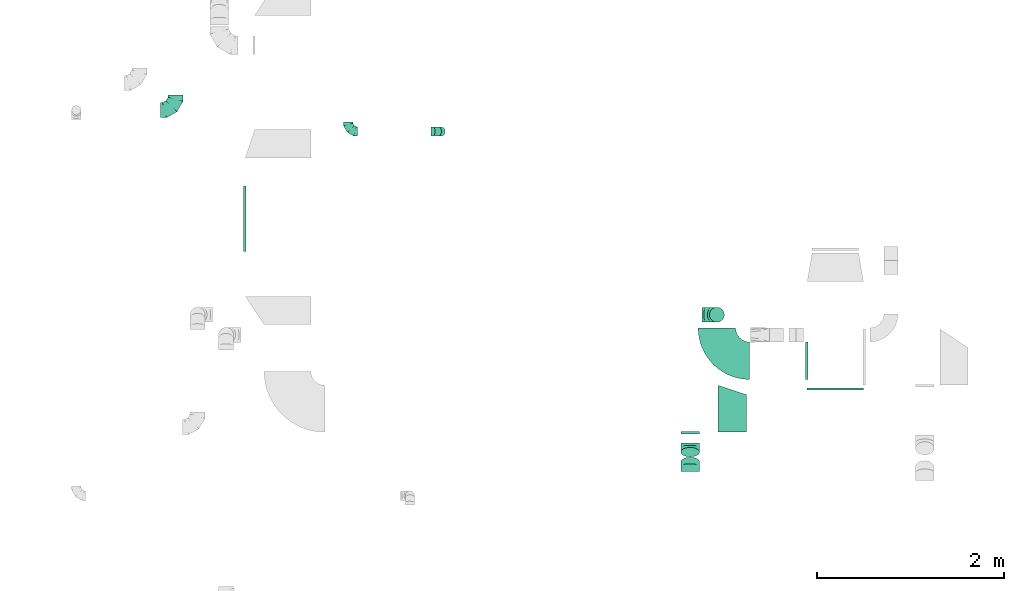
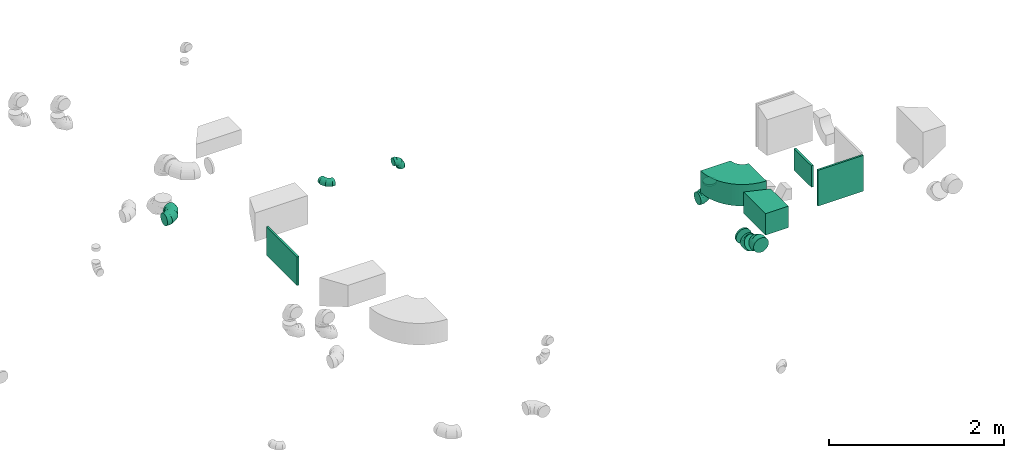
# One storey, part 9 of 32: 13 flow fittings.
"""IFC2X3 building model written with IfcOpenShell, lengths in millimetres."""

import ifcopenshell
import ifcopenshell.guid

model = None  # the IFC model being written
_history = None  # IfcOwnerHistory: only IFC2X3 demands one
_inside = {}  # id of a spatial element -> (the spatial element, [elements in it])
_under = {}  # id of a project, library or spatial element -> (it, [spatial elements below it])
_declared = {}  # id of a project -> (the project, [libraries it declares])
_typed = {}  # id of a type object -> (the type object, [elements of that type])
_made_of = {}  # id of a material, layer set ... -> (it, [elements and type objects made of it])


def new_model(schema):
    """Start an empty IFC model of exactly this schema.

    Asked for "IFC4X3", IfcOpenShell would pick the latest addendum, in which some entities
    have other attributes; the version numbers below select the first issue.
    IFC2X3 requires an IfcOwnerHistory on every rooted entity: one is made here for all.
    """
    global model, _history
    if schema == "IFC4X3":
        model = ifcopenshell.file(schema_version=(4, 3, 0, 0))
    else:
        model = ifcopenshell.file(schema=schema)
    _inside.clear()
    _under.clear()
    _declared.clear()
    _typed.clear()
    _made_of.clear()
    _history = None
    if model.schema == "IFC2X3":
        org = make("IfcOrganization", Name="unknown")
        user = make(
            "IfcPersonAndOrganization",
            ThePerson=make("IfcPerson", FamilyName="unknown"),
            TheOrganization=org,
        )
        app = make(
            "IfcApplication",
            ApplicationDeveloper=org,
            Version="unknown",
            ApplicationFullName="unknown",
            ApplicationIdentifier="unknown",
        )
        _history = make(
            "IfcOwnerHistory",
            OwningUser=user,
            OwningApplication=app,
            ChangeAction="ADDED",
            CreationDate=0,
        )
    return model


def make(cls, **values):
    """One entity of the class cls with the attributes given. An attribute that is None is left unset."""
    return model.create_entity(
        cls, **{name: value for name, value in values.items() if value is not None}
    )


def entity(cls, *values):
    """Any entity or typed value of the class cls, its attributes in the order of the schema. None: left unset."""
    e = model.create_entity(cls)
    for i, value in enumerate(values):
        if value is not None:
            e[i] = value
    return e


def rooted(cls, **values):
    """An entity with a GlobalId (a new one), such as an element, a storey or a relation."""
    return make(cls, GlobalId=ifcopenshell.guid.new(), OwnerHistory=_history, **values)


def si_unit(unit_type, name, prefix=None):
    """IfcSIUnit, for example si_unit("LENGTHUNIT", "METRE", prefix="MILLI")."""
    return make("IfcSIUnit", UnitType=unit_type, Prefix=prefix, Name=name)


def converted_unit(unit_type, name, factor, base, dimensions=None, offset=None):
    """IfcConversionBasedUnit, such as the inch: factor (a typed value) times the base unit."""
    return make(
        "IfcConversionBasedUnit"
        if offset is None
        else "IfcConversionBasedUnitWithOffset",
        ConversionOffset=offset,
        Dimensions=None
        if dimensions is None
        else entity("IfcDimensionalExponents", *dimensions),
        UnitType=unit_type,
        Name=name,
        ConversionFactor=make(
            "IfcMeasureWithUnit", ValueComponent=factor, UnitComponent=base
        ),
    )


def derived_unit(unit_type, elements):
    """IfcDerivedUnit: a product of units, each with its exponent."""
    return make(
        "IfcDerivedUnit",
        Elements=[
            make("IfcDerivedUnitElement", Unit=unit, Exponent=power)
            for unit, power in elements
        ],
        UnitType=unit_type,
    )


def assignment(units):
    """IfcUnitAssignment: the units of a project."""
    return None if units is None else make("IfcUnitAssignment", Units=units)


def point(xyz):
    """IfcCartesianPoint."""
    return None if xyz is None else make("IfcCartesianPoint", Coordinates=xyz)


def direction(xyz):
    """IfcDirection."""
    return None if xyz is None else make("IfcDirection", DirectionRatios=xyz)


def frame(location, z_axis=None, x_axis=None):
    """IfcAxis2Placement3D, a coordinate frame: its origin and axes. An axis left out is left unset."""
    return make(
        "IfcAxis2Placement3D",
        Location=point(location),
        Axis=direction(z_axis),
        RefDirection=direction(x_axis),
    )


def frame_2d(location, x_axis=None):
    """IfcAxis2Placement2D, a coordinate frame in the plane: its origin and x axis."""
    return make(
        "IfcAxis2Placement2D", Location=point(location), RefDirection=direction(x_axis)
    )


def origin():
    """The frame at (0, 0, 0) with its axes left unset."""
    return frame((0.0, 0.0, 0.0))


def origin_2d_with_axis():
    """The frame at (0, 0) in the plane with the x axis (1, 0) written out."""
    return frame_2d((0.0, 0.0), x_axis=(1.0, 0.0))


def place(relative_to, where):
    """IfcLocalPlacement: puts the frame where relative to a parent placement (None: the world)."""
    return make(
        "IfcLocalPlacement", PlacementRelTo=relative_to, RelativePlacement=where
    )


def context(
    kind, dimensions, precision=None, world=None, true_north=None, identifier=None
):
    """IfcGeometricRepresentationContext, for example the 3D "Model" context."""
    return make(
        "IfcGeometricRepresentationContext",
        ContextIdentifier=identifier,
        ContextType=kind,
        CoordinateSpaceDimension=dimensions,
        Precision=precision,
        WorldCoordinateSystem=world,
        TrueNorth=true_north,
    )


def subcontext(parent, identifier, kind, view, scale=None):
    """IfcGeometricRepresentationSubContext, for example "Body" below "Model"."""
    return make(
        "IfcGeometricRepresentationSubContext",
        ContextIdentifier=identifier,
        ContextType=kind,
        ParentContext=parent,
        TargetScale=scale,
        TargetView=view,
    )


def project(units=None, contexts=None):
    """IfcProject with its units and contexts."""
    return rooted(
        "IfcProject",
        Name="project",
        RepresentationContexts=contexts,
        UnitsInContext=assignment(units),
    )


def spatial(cls, under=None, at=None, **own):
    """A site, building, storey or space (cls), placed at a placement, below another one or the project."""
    s = rooted(cls, ObjectPlacement=at, **own)
    if under is not None:
        _under.setdefault(under.id(), (under, []))[1].append(s)
    return s


def polyline(points):
    """IfcPolyline through the points."""
    return make("IfcPolyline", Points=[point(p) for p in points])


def circle_curve(where, radius):
    """IfcCircle in the frame where."""
    return make("IfcCircle", Position=where, Radius=radius)


def parameter(value):
    """IfcParameterValue: where a trimmed curve begins or ends, as a parameter of its basis curve."""
    return model.create_entity("IfcParameterValue", value)


def trimmed(basis, trim1, trim2, sense, master):
    """IfcTrimmedCurve: the piece of a basis curve between two trims."""
    return make(
        "IfcTrimmedCurve",
        BasisCurve=basis,
        Trim1=trim1,
        Trim2=trim2,
        SenseAgreement=sense,
        MasterRepresentation=master,
    )


def segment(curve, same_sense, transition):
    """IfcCompositeCurveSegment."""
    return make(
        "IfcCompositeCurveSegment",
        Transition=transition,
        SameSense=same_sense,
        ParentCurve=curve,
    )


def composite_curve(segments, self_intersect=None):
    """IfcCompositeCurve: segments joined end to end."""
    return make("IfcCompositeCurve", Segments=segments, SelfIntersect=self_intersect)


def profile(cls, at=None, kind="AREA", **sizes):
    """A parametric profile (cls). Its sizes go by their IFC names, for example OverallWidth=200.0."""
    return make(cls, ProfileType=kind, Position=at, **sizes)


def rectangle(**sizes):
    """IfcRectangleProfileDef."""
    return profile("IfcRectangleProfileDef", **sizes)


def outline(outer, holes=None, kind="AREA"):
    """IfcArbitraryClosedProfileDef: a profile drawn as a closed curve; with holes, ...WithVoids."""
    if holes is None:
        return make("IfcArbitraryClosedProfileDef", ProfileType=kind, OuterCurve=outer)
    return make(
        "IfcArbitraryProfileDefWithVoids",
        ProfileType=kind,
        OuterCurve=outer,
        InnerCurves=holes,
    )


def extrude(swept, where, along, depth):
    """IfcExtrudedAreaSolid: the profile swept, set in the frame where, extruded along a direction by depth."""
    return make(
        "IfcExtrudedAreaSolid",
        SweptArea=swept,
        Position=where,
        ExtrudedDirection=direction(along),
        Depth=depth,
    )


def faces_of(points, faces, orient=None, outer=None):
    """IfcFace entities. A face is a list of loops; a loop is a list of indices into points, from 0.

    orient and outer hold one flag for each loop. By default every Orientation is true, the
    first loop of a face is its IfcFaceOuterBound and the others are IfcFaceBound.
    """
    made = []
    for i, loops in enumerate(faces):
        bounds = []
        for j, loop in enumerate(loops):
            is_outer = j == 0 if outer is None else outer[i][j]
            bounds.append(
                make(
                    "IfcFaceOuterBound" if is_outer else "IfcFaceBound",
                    Bound=make("IfcPolyLoop", Polygon=[points[k] for k in loop]),
                    Orientation=True if orient is None else orient[i][j],
                )
            )
        made.append(make("IfcFace", Bounds=bounds))
    return made


def faceted_brep(points, faces, orient=None, outer=None, voids=None):
    """IfcFacetedBrep: a solid bounded by flat faces; with voids (closed shells), ...WithVoids."""
    shared = [point(p) for p in points]
    hull = make("IfcClosedShell", CfsFaces=faces_of(shared, faces, orient, outer))
    if voids is None:
        return make("IfcFacetedBrep", Outer=hull)
    return make(
        "IfcFacetedBrepWithVoids",
        Outer=hull,
        Voids=[
            make(cls, CfsFaces=faces_of(shared, fs, o, b)) for cls, fs, o, b in voids
        ],
    )


def shape(context_of_items, identifier, shape_type, items):
    """IfcShapeRepresentation: the items that make up one representation, for example the "Body"."""
    return make(
        "IfcShapeRepresentation",
        ContextOfItems=context_of_items,
        RepresentationIdentifier=identifier,
        RepresentationType=shape_type,
        Items=items,
    )


def source(mapping_origin, context_of_items, identifier, shape_type, items):
    """IfcRepresentationMap: a shape defined once, which mapped items show again and again."""
    return make(
        "IfcRepresentationMap",
        MappingOrigin=mapping_origin,
        MappedRepresentation=shape(context_of_items, identifier, shape_type, items),
    )


def transform(
    local_origin,
    x_axis=None,
    y_axis=None,
    z_axis=None,
    scale=None,
    scale2=None,
    scale3=None,
    uniform=True,
):
    """IfcCartesianTransformationOperator3D, or its non-uniform kind. x_axis, y_axis, z_axis: its Axis1, 2, 3."""
    if uniform:
        return make(
            "IfcCartesianTransformationOperator3D",
            Axis1=direction(x_axis),
            Axis2=direction(y_axis),
            LocalOrigin=point(local_origin),
            Scale=scale,
            Axis3=direction(z_axis),
        )
    return make(
        "IfcCartesianTransformationOperator3DnonUniform",
        Axis1=direction(x_axis),
        Axis2=direction(y_axis),
        LocalOrigin=point(local_origin),
        Scale=scale,
        Axis3=direction(z_axis),
        Scale2=scale2,
        Scale3=scale3,
    )


def mapped(mapping_source, mapping_target):
    """IfcMappedItem: shows the shape of a source again, moved by a transform."""
    return make(
        "IfcMappedItem", MappingSource=mapping_source, MappingTarget=mapping_target
    )


def material(Name=None, Category=None):
    """IfcMaterial."""
    return make("IfcMaterial", Name=Name, Category=Category)


def made_of(thing, what):
    """Note that an element or type object is made of a material, layer set ...; save() writes the relation."""
    if what is not None:
        _made_of.setdefault(what.id(), (what, []))[1].append(thing)
    return thing


def type_object(cls, material=None, **own):
    """A type object (cls), such as IfcWallType, which elements share."""
    return made_of(rooted(cls, **own), material)


def type_shapes(of_type, sources):
    """Give a type object the sources (RepresentationMaps) that its elements show as mapped items."""
    of_type.RepresentationMaps = sources


def element(
    cls,
    number,
    at=None,
    inside=None,
    cuts=None,
    type_object=None,
    material=None,
    context=None,
    identifier="Body",
    shape_type=None,
    held_by="IfcProductDefinitionShape",
    body=None,
    shapes=None,
    **own,
):
    """One element of the class cls, such as IfcWall. Its Tag is "e" and its number.

    at: its placement. inside: the storey or other place that contains it. cuts: it is an
    opening in that element (IfcRelVoidsElement). A single representation is given by context,
    identifier, shape_type and body (its items); several are given by shapes. held_by: the class
    of the entity that holds the representations. save() writes the other relations.
    """
    e = rooted(cls, Tag="e%d" % number, ObjectPlacement=at, **own)
    if body is not None:
        shapes = [shape(context, identifier, shape_type, body)]
    if shapes is not None:
        e.Representation = make(held_by, Representations=shapes)
    if inside is not None:
        _inside.setdefault(inside.id(), (inside, []))[1].append(e)
    if cuts is not None:
        rooted(
            "IfcRelVoidsElement", RelatingBuildingElement=cuts, RelatedOpeningElement=e
        )
    if type_object is not None:
        _typed.setdefault(type_object.id(), (type_object, []))[1].append(e)
    return made_of(e, material)


def aggregate(whole, parts):
    """IfcRelAggregates: a whole, such as a stair, and the parts it consists of."""
    return rooted("IfcRelAggregates", RelatingObject=whole, RelatedObjects=parts)


def save(model, path):
    """Write the relations noted so far, then the file.

    IfcRelAggregates (storeys below a building ...), IfcRelContainedInSpatialStructure (elements
    in a storey), IfcRelDefinesByType, IfcRelAssociatesMaterial and IfcRelDeclares: one each for
    every whole, place, type object, material and project.
    """
    for whole, parts in _under.values():
        aggregate(whole, parts)
    for where, things in _inside.values():
        rooted(
            "IfcRelContainedInSpatialStructure",
            RelatedElements=things,
            RelatingStructure=where,
        )
    for kind, things in _typed.values():
        rooted("IfcRelDefinesByType", RelatedObjects=things, RelatingType=kind)
    for what, things in _made_of.values():
        rooted("IfcRelAssociatesMaterial", RelatedObjects=things, RelatingMaterial=what)
    for by, libraries in _declared.values():
        rooted("IfcRelDeclares", RelatingContext=by, RelatedDefinitions=libraries)
    model.write(path)


model = new_model("IFC2X3")

# Units and contexts
model_context = context("Model", 3, precision=0.01, world=origin(), true_north=direction((6.12303176911189e-17, 1.0)))
body_context = subcontext(model_context, "Body", "Model", "MODEL_VIEW")
ifc_project = project(units=[si_unit("LENGTHUNIT", "METRE", prefix="MILLI"), si_unit("AREAUNIT", "SQUARE_METRE"), si_unit("VOLUMEUNIT", "CUBIC_METRE"), converted_unit("PLANEANGLEUNIT", "DEGREE", entity("IfcRatioMeasure", 0.0174532925199433), si_unit("PLANEANGLEUNIT", "RADIAN"), dimensions=[0, 0, 0, 0, 0, 0, 0]), si_unit("MASSUNIT", "GRAM", prefix="KILO"), derived_unit("MASSDENSITYUNIT", [(si_unit("MASSUNIT", "GRAM", prefix="KILO"), 1), (si_unit("LENGTHUNIT", "METRE"), -3)]), derived_unit("MOMENTOFINERTIAUNIT", [(si_unit("LENGTHUNIT", "METRE"), 4)]), si_unit("TIMEUNIT", "SECOND"), si_unit("FREQUENCYUNIT", "HERTZ"), si_unit("THERMODYNAMICTEMPERATUREUNIT", "DEGREE_CELSIUS"), derived_unit("THERMALTRANSMITTANCEUNIT", [(si_unit("MASSUNIT", "GRAM", prefix="KILO"), 1), (si_unit("THERMODYNAMICTEMPERATUREUNIT", "KELVIN"), -1), (si_unit("TIMEUNIT", "SECOND"), -3)]), derived_unit("VOLUMETRICFLOWRATEUNIT", [(si_unit("LENGTHUNIT", "METRE"), 3), (si_unit("TIMEUNIT", "SECOND"), -1)]), derived_unit("MASSFLOWRATEUNIT", [(si_unit("MASSUNIT", "GRAM", prefix="KILO"), 1), (si_unit("TIMEUNIT", "SECOND"), -1)]), derived_unit("ROTATIONALFREQUENCYUNIT", [(si_unit("TIMEUNIT", "SECOND"), -1)]), si_unit("ELECTRICCURRENTUNIT", "AMPERE"), si_unit("ELECTRICVOLTAGEUNIT", "VOLT"), si_unit("POWERUNIT", "WATT"), si_unit("FORCEUNIT", "NEWTON", prefix="KILO"), si_unit("ILLUMINANCEUNIT", "LUX"), si_unit("LUMINOUSFLUXUNIT", "LUMEN"), si_unit("LUMINOUSINTENSITYUNIT", "CANDELA"), derived_unit("USERDEFINED", [(si_unit("MASSUNIT", "GRAM", prefix="KILO"), -1), (si_unit("LENGTHUNIT", "METRE"), -2), (si_unit("TIMEUNIT", "SECOND"), 3), (si_unit("LUMINOUSFLUXUNIT", "LUMEN"), 1)]), derived_unit("LINEARVELOCITYUNIT", [(si_unit("LENGTHUNIT", "METRE"), 1), (si_unit("TIMEUNIT", "SECOND"), -1)]), si_unit("PRESSUREUNIT", "PASCAL"), derived_unit("USERDEFINED", [(si_unit("LENGTHUNIT", "METRE"), -2), (si_unit("MASSUNIT", "GRAM", prefix="KILO"), 1), (si_unit("TIMEUNIT", "SECOND"), -2)]), derived_unit("LINEARFORCEUNIT", [(si_unit("MASSUNIT", "GRAM", prefix="KILO"), 1), (si_unit("LENGTHUNIT", "METRE"), 1), (si_unit("TIMEUNIT", "SECOND"), -2), (si_unit("LENGTHUNIT", "METRE"), -1)]), derived_unit("PLANARFORCEUNIT", [(si_unit("MASSUNIT", "GRAM", prefix="KILO"), 1), (si_unit("LENGTHUNIT", "METRE"), 1), (si_unit("TIMEUNIT", "SECOND"), -2), (si_unit("LENGTHUNIT", "METRE"), -2)])], contexts=[model_context])

# Site, building, storey
site_placement = place(None, origin())
site = spatial("IfcSite", under=ifc_project, at=site_placement, CompositionType="ELEMENT")
building_placement = place(site_placement, origin())
building = spatial("IfcBuilding", under=site, at=building_placement, CompositionType="ELEMENT")
storey_placement = place(building_placement, frame((0.0, 0.0, 8100.0)))
storey = spatial("IfcBuildingStorey", under=building, at=storey_placement, CompositionType="ELEMENT", Elevation=8100.0)

# Flow fittings
ifc_material = material()
duct_fitting_type_1 = type_object("IfcDuctFittingType", PredefinedType="NOTDEFINED", material=ifc_material)
shared_shape_1 = source(origin(), body_context, "Body", "SweptSolid", [
    extrude(rectangle(XDim=24.9999999999999, YDim=600.0, at=origin_2d_with_axis()), frame((12.5, 0.0, -250.0)), (0.0, 0.0, 1.0), 500.0),
])
type_shapes(duct_fitting_type_1, [shared_shape_1])
flow_fitting_1_placement = place(storey_placement, frame((24342.3, 9460.54, 3200.0), z_axis=(0.0, 0.0, 1.0), x_axis=(0.0, -1.0, 0.0)))
element("IfcFlowFitting", 1, at=flow_fitting_1_placement, inside=storey, type_object=duct_fitting_type_1, material=ifc_material, context=body_context, shape_type="MappedRepresentation", body=[
    mapped(shared_shape_1, transform((0.0, 0.0, 0.0), scale=1.0)),
])
duct_fitting_type_2 = type_object("IfcDuctFittingType", PredefinedType="NOTDEFINED", material=ifc_material)
shared_shape_2 = source(origin(), body_context, "Body", "SweptSolid", [
    extrude(outline(polyline([(-86.96, -213.45), (229.27, -213.45), (71.15, 260.89), (-213.45, 166.02), (-86.96, -213.45)])), frame((150.0, -25.0, -150.0), z_axis=(0.0, 0.0, 1.0), x_axis=(0.9486832980505, -0.316227766016878, 0.0)), (0.0, 0.0, 1.0), 300.0),
])
type_shapes(duct_fitting_type_2, [shared_shape_2])
flow_fitting_2_placement = place(storey_placement, frame((23391.81, 9187.88, 3300.0), z_axis=(0.0, 0.0, 1.0), x_axis=(-1.0, 0.0, 0.0)))
element("IfcFlowFitting", 2, at=flow_fitting_2_placement, inside=storey, type_object=duct_fitting_type_2, material=ifc_material, context=body_context, shape_type="MappedRepresentation", body=[
    mapped(shared_shape_2, transform((0.0, 0.0, 0.0), scale=1.0)),
])
duct_fitting_type_3 = type_object("IfcDuctFittingType", PredefinedType="NOTDEFINED", material=ifc_material)
shared_shape_3 = source(origin(), body_context, "Body", "SweptSolid", [
    extrude(rectangle(XDim=26.0960000000054, YDim=700.0, at=origin_2d_with_axis()), frame((6.95, 0.0, -200.0)), (0.0, 0.0, 1.0), 400.0),
])
type_shapes(duct_fitting_type_3, [shared_shape_3])
flow_fitting_3_placement = place(storey_placement, frame((18041.81, 11267.22, 3250.0), z_axis=(0.0, 0.0, -1.0), x_axis=(-1.0, 0.0, 0.0)))
element("IfcFlowFitting", 3, at=flow_fitting_3_placement, inside=storey, type_object=duct_fitting_type_3, material=ifc_material, context=body_context, shape_type="MappedRepresentation", body=[
    mapped(shared_shape_3, transform((0.0, 0.0, 0.0), scale=1.0)),
])
duct_fitting_type_4 = type_object("IfcDuctFittingType", PredefinedType="NOTDEFINED", material=ifc_material)
shared_shape_4 = source(origin(), body_context, "Body", "SweptSolid", [
    extrude(rectangle(XDim=26.0960000000006, YDim=400.0, at=origin_2d_with_axis()), frame((6.95, 0.0, -150.0)), (0.0, 0.0, 1.0), 300.0),
])
type_shapes(duct_fitting_type_4, [shared_shape_4])
flow_fitting_4_placement = place(storey_placement, frame((24042.3, 9750.83, 3300.0), z_axis=(0.0, 0.0, -1.0), x_axis=(-1.0, 0.0, 0.0)))
element("IfcFlowFitting", 4, at=flow_fitting_4_placement, inside=storey, type_object=duct_fitting_type_4, material=ifc_material, context=body_context, shape_type="MappedRepresentation", body=[
    mapped(shared_shape_4, transform((0.0, 0.0, 0.0), scale=1.0)),
])
duct_fitting_type_5 = type_object("IfcDuctFittingType", PredefinedType="NOTDEFINED", material=ifc_material)
shared_shape_5 = source(origin(), body_context, "Body", "Brep", [
    faceted_brep([(-160.0, 0.0, -80.0), (-160.0, -20.71, -77.27), (-160.0, -40.0, -69.28), (-160.0, -56.57, -56.57), (-160.0, -69.28, -40.0), (-160.0, -77.27, -20.71), (-160.0, -80.0, 0.0), (-160.0, -77.27, 20.71), (-160.0, -69.28, 40.0), (-160.0, -56.57, 56.57), (-160.0, -40.0, 69.28), (-160.0, -20.71, 77.27), (-160.0, 0.0, 80.0), (-160.0, 20.71, 77.27), (-160.0, 40.0, 69.28), (-160.0, 56.57, 56.57), (-160.0, 69.28, 40.0), (-160.0, 77.27, 20.71), (-160.0, 80.0, 0.0), (-160.0, 77.27, -20.71), (-160.0, 69.28, -40.0), (-160.0, 56.57, -56.57), (-160.0, 40.0, -69.28), (-160.0, 20.71, -77.27), (-122.68, 20.71, 77.27), (-127.85, 40.0, 69.28), (-117.13, 0.0, 80.0), (-132.29, 56.57, 56.57), (-137.83, 77.27, 20.71), (-138.56, 80.0, 0.0), (-135.69, 69.28, 40.0), (-135.69, 69.28, -40.0), (-132.29, 56.57, -56.57), (-137.83, 77.27, -20.71), (-122.68, 20.71, -77.27), (-117.13, 0.0, -80.0), (-127.85, 40.0, -69.28), (-111.58, -20.71, -77.27), (-106.41, -40.0, -69.28), (-101.97, -56.57, -56.57), (-98.56, -69.28, -40.0), (-96.42, -77.27, -20.71), (-95.69, -80.0, 0.0), (-96.42, -77.27, 20.71), (-98.56, -69.28, 40.0), (-101.97, -56.57, 56.57), (-106.41, -40.0, 69.28), (-111.58, -20.71, 77.27), (-58.03, 58.03, 77.27), (-72.15, 72.15, 69.28), (-42.87, 42.87, 80.0), (-84.28, 84.28, 56.57), (-93.59, 93.59, 40.0), (-99.44, 99.44, 20.71), (-101.44, 101.44, 0.0), (-99.44, 99.44, -20.71), (-93.59, 93.59, -40.0), (-84.28, 84.28, -56.57), (-58.03, 58.03, -77.27), (-42.87, 42.87, -80.0), (-72.15, 72.15, -69.28), (-27.71, 27.71, -77.27), (-13.59, 13.59, -69.28), (-1.46, 1.46, -56.57), (7.85, -7.85, -40.0), (13.7, -13.7, -20.71), (15.69, -15.69, 0.0), (13.7, -13.7, 20.71), (7.85, -7.85, 40.0), (-1.46, 1.46, 56.57), (-13.59, 13.59, 69.28), (-27.71, 27.71, 77.27), (-20.71, 122.68, 77.27), (-40.0, 127.85, 69.28), (0.0, 117.13, 80.0), (-56.57, 132.29, 56.57), (-69.28, 135.69, 40.0), (-77.27, 137.83, 20.71), (-80.0, 138.56, 0.0), (-77.27, 137.83, -20.71), (-69.28, 135.69, -40.0), (-56.57, 132.29, -56.57), (-20.71, 122.68, -77.27), (0.0, 117.13, -80.0), (-40.0, 127.85, -69.28), (20.71, 111.58, -77.27), (40.0, 106.41, -69.28), (56.57, 101.97, -56.57), (69.28, 98.56, -40.0), (77.27, 96.42, -20.71), (80.0, 95.69, 0.0), (77.27, 96.42, 20.71), (69.28, 98.56, 40.0), (56.57, 101.97, 56.57), (40.0, 106.41, 69.28), (20.71, 111.58, 77.27), (-20.71, 160.0, -77.27), (-40.0, 160.0, -69.28), (-56.57, 160.0, -56.57), (-69.28, 160.0, -40.0), (-77.27, 160.0, -20.71), (-80.0, 160.0, 0.0), (-77.27, 160.0, 20.71), (-69.28, 160.0, 40.0), (-56.57, 160.0, 56.57), (-40.0, 160.0, 69.28), (-20.71, 160.0, 77.27), (0.0, 160.0, 80.0), (20.71, 160.0, 77.27), (40.0, 160.0, 69.28), (56.57, 160.0, 56.57), (69.28, 160.0, 40.0), (77.27, 160.0, 20.71), (80.0, 160.0, 0.0), (77.27, 160.0, -20.71), (69.28, 160.0, -40.0), (56.57, 160.0, -56.57), (40.0, 160.0, -69.28), (20.71, 160.0, -77.27), (0.0, 160.0, -80.0)], [[[0, 1, 2, 3, 4, 5, 6, 7, 8, 9, 10, 11, 12, 13, 14, 15, 16, 17, 18, 19, 20, 21, 22, 23]], [[24, 25, 14, 13]], [[26, 24, 13, 12]], [[14, 25, 27, 15]], [[28, 29, 18, 17]], [[30, 28, 17, 16]], [[15, 27, 30, 16]], [[20, 31, 32, 21]], [[33, 31, 20, 19]], [[18, 29, 33, 19]], [[34, 35, 0, 23]], [[36, 34, 23, 22]], [[32, 36, 22, 21]], [[1, 0, 35, 37]], [[2, 1, 37, 38]], [[3, 2, 38, 39]], [[5, 4, 40, 41]], [[6, 5, 41, 42]], [[39, 40, 4, 3]], [[6, 42, 43, 7]], [[7, 43, 44, 8]], [[8, 44, 45, 9]], [[9, 45, 46, 10]], [[10, 46, 47, 11]], [[26, 12, 11, 47]], [[48, 49, 25, 24]], [[50, 48, 24, 26]], [[27, 25, 49, 51]], [[52, 53, 28, 30]], [[51, 52, 30, 27]], [[29, 28, 53, 54]], [[55, 56, 31, 33]], [[54, 55, 33, 29]], [[32, 31, 56, 57]], [[58, 59, 35, 34]], [[60, 58, 34, 36]], [[57, 60, 36, 32]], [[37, 35, 59, 61]], [[38, 37, 61, 62]], [[39, 38, 62, 63]], [[41, 40, 64, 65]], [[42, 41, 65, 66]], [[63, 64, 40, 39]], [[43, 42, 66, 67]], [[44, 43, 67, 68]], [[68, 69, 45, 44]], [[46, 45, 69, 70]], [[47, 46, 70, 71]], [[26, 47, 71, 50]], [[72, 73, 49, 48]], [[74, 72, 48, 50]], [[51, 49, 73, 75]], [[76, 77, 53, 52]], [[75, 76, 52, 51]], [[54, 53, 77, 78]], [[79, 80, 56, 55]], [[78, 79, 55, 54]], [[57, 56, 80, 81]], [[82, 83, 59, 58]], [[84, 82, 58, 60]], [[81, 84, 60, 57]], [[61, 59, 83, 85]], [[62, 61, 85, 86]], [[63, 62, 86, 87]], [[65, 64, 88, 89]], [[66, 65, 89, 90]], [[87, 88, 64, 63]], [[67, 66, 90, 91]], [[68, 67, 91, 92]], [[92, 93, 69, 68]], [[70, 69, 93, 94]], [[71, 70, 94, 95]], [[50, 71, 95, 74]], [[96, 97, 98, 99, 100, 101, 102, 103, 104, 105, 106, 107, 108, 109, 110, 111, 112, 113, 114, 115, 116, 117, 118, 119]], [[72, 74, 107, 106]], [[73, 72, 106, 105]], [[75, 73, 105, 104]], [[77, 76, 103, 102]], [[78, 77, 102, 101]], [[75, 104, 103, 76]], [[78, 101, 100, 79]], [[79, 100, 99, 80]], [[80, 99, 98, 81]], [[84, 97, 96, 82]], [[82, 96, 119, 83]], [[84, 81, 98, 97]], [[118, 117, 86, 85]], [[119, 118, 85, 83]], [[116, 87, 86, 117]], [[88, 115, 114, 89]], [[89, 114, 113, 90]], [[115, 88, 87, 116]], [[112, 111, 92, 91]], [[113, 112, 91, 90]], [[111, 110, 93, 92]], [[95, 94, 109, 108]], [[74, 95, 108, 107]], [[110, 109, 94, 93]]]),
])
type_shapes(duct_fitting_type_5, [shared_shape_5])
flow_fitting_5_placement = place(storey_placement, frame((23077.3, 10241.51, 2965.0), z_axis=(0.0, -1.0, 0.0), x_axis=(1.0, 0.0, 0.0)))
element("IfcFlowFitting", 5, at=flow_fitting_5_placement, inside=storey, type_object=duct_fitting_type_5, material=ifc_material, context=body_context, shape_type="MappedRepresentation", body=[
    mapped(shared_shape_5, transform((0.0, 0.0, 0.0), scale=1.0)),
])
flow_fitting_6_placement = place(storey_placement, frame((17297.33, 12425.69, 3370.0)))
element("IfcFlowFitting", 6, at=flow_fitting_6_placement, inside=storey, type_object=duct_fitting_type_5, material=ifc_material, context=body_context, shape_type="MappedRepresentation", body=[
    mapped(shared_shape_5, transform((0.0, 0.0, 0.0), scale=1.0)),
])
duct_fitting_type_6 = type_object("IfcDuctFittingType", PredefinedType="NOTDEFINED", material=ifc_material)
shared_shape_6 = source(origin(), body_context, "Body", "Brep", [
    faceted_brep([(-100.0, 0.0, -50.0), (-100.0, -12.94, -48.3), (-100.0, -25.0, -43.3), (-100.0, -35.36, -35.36), (-100.0, -43.3, -25.0), (-100.0, -48.3, -12.94), (-100.0, -50.0, 0.0), (-100.0, -48.3, 12.94), (-100.0, -43.3, 25.0), (-100.0, -35.36, 35.36), (-100.0, -25.0, 43.3), (-100.0, -12.94, 48.3), (-100.0, 0.0, 50.0), (-100.0, 12.94, 48.3), (-100.0, 25.0, 43.3), (-100.0, 35.36, 35.36), (-100.0, 43.3, 25.0), (-100.0, 48.3, 12.94), (-100.0, 50.0, 0.0), (-100.0, 48.3, -12.94), (-100.0, 43.3, -25.0), (-100.0, 35.36, -35.36), (-100.0, 25.0, -43.3), (-100.0, 12.94, -48.3), (-76.67, 12.94, 48.3), (-79.9, 25.0, 43.3), (-73.21, 0.0, 50.0), (-82.68, 35.36, 35.36), (-86.15, 48.3, 12.94), (-86.6, 50.0, 0.0), (-84.81, 43.3, 25.0), (-84.81, 43.3, -25.0), (-82.68, 35.36, -35.36), (-86.15, 48.3, -12.94), (-76.67, 12.94, -48.3), (-73.21, 0.0, -50.0), (-79.9, 25.0, -43.3), (-69.74, -12.94, -48.3), (-66.51, -25.0, -43.3), (-63.73, -35.36, -35.36), (-61.6, -43.3, -25.0), (-60.26, -48.3, -12.94), (-59.81, -50.0, 0.0), (-60.26, -48.3, 12.94), (-61.6, -43.3, 25.0), (-63.73, -35.36, 35.36), (-66.51, -25.0, 43.3), (-69.74, -12.94, 48.3), (-36.27, 36.27, 48.3), (-45.1, 45.1, 43.3), (-26.79, 26.79, 50.0), (-52.68, 52.68, 35.36), (-58.49, 58.49, 25.0), (-62.15, 62.15, 12.94), (-63.4, 63.4, 0.0), (-62.15, 62.15, -12.94), (-58.49, 58.49, -25.0), (-52.68, 52.68, -35.36), (-36.27, 36.27, -48.3), (-26.79, 26.79, -50.0), (-45.1, 45.1, -43.3), (-17.32, 17.32, -48.3), (-8.49, 8.49, -43.3), (-0.91, 0.91, -35.36), (4.9, -4.9, -25.0), (8.56, -8.56, -12.94), (9.81, -9.81, 0.0), (8.56, -8.56, 12.94), (4.9, -4.9, 25.0), (-0.91, 0.91, 35.36), (-8.49, 8.49, 43.3), (-17.32, 17.32, 48.3), (-12.94, 76.67, 48.3), (-25.0, 79.9, 43.3), (0.0, 73.21, 50.0), (-35.36, 82.68, 35.36), (-43.3, 84.81, 25.0), (-48.3, 86.15, 12.94), (-50.0, 86.6, 0.0), (-48.3, 86.15, -12.94), (-43.3, 84.81, -25.0), (-35.36, 82.68, -35.36), (-12.94, 76.67, -48.3), (0.0, 73.21, -50.0), (-25.0, 79.9, -43.3), (12.94, 69.74, -48.3), (25.0, 66.51, -43.3), (35.36, 63.73, -35.36), (43.3, 61.6, -25.0), (48.3, 60.26, -12.94), (50.0, 59.81, 0.0), (48.3, 60.26, 12.94), (43.3, 61.6, 25.0), (35.36, 63.73, 35.36), (25.0, 66.51, 43.3), (12.94, 69.74, 48.3), (-12.94, 100.0, -48.3), (-25.0, 100.0, -43.3), (-35.36, 100.0, -35.36), (-43.3, 100.0, -25.0), (-48.3, 100.0, -12.94), (-50.0, 100.0, 0.0), (-48.3, 100.0, 12.94), (-43.3, 100.0, 25.0), (-35.36, 100.0, 35.36), (-25.0, 100.0, 43.3), (-12.94, 100.0, 48.3), (0.0, 100.0, 50.0), (12.94, 100.0, 48.3), (25.0, 100.0, 43.3), (35.36, 100.0, 35.36), (43.3, 100.0, 25.0), (48.3, 100.0, 12.94), (50.0, 100.0, 0.0), (48.3, 100.0, -12.94), (43.3, 100.0, -25.0), (35.36, 100.0, -35.36), (25.0, 100.0, -43.3), (12.94, 100.0, -48.3), (0.0, 100.0, -50.0)], [[[0, 1, 2, 3, 4, 5, 6, 7, 8, 9, 10, 11, 12, 13, 14, 15, 16, 17, 18, 19, 20, 21, 22, 23]], [[24, 25, 14, 13]], [[26, 24, 13, 12]], [[14, 25, 27, 15]], [[28, 29, 18, 17]], [[30, 28, 17, 16]], [[15, 27, 30, 16]], [[20, 31, 32, 21]], [[33, 31, 20, 19]], [[18, 29, 33, 19]], [[34, 35, 0, 23]], [[36, 34, 23, 22]], [[32, 36, 22, 21]], [[2, 1, 37, 38]], [[3, 2, 38, 39]], [[0, 35, 37, 1]], [[5, 4, 40, 41]], [[6, 5, 41, 42]], [[3, 39, 40, 4]], [[6, 42, 43, 7]], [[7, 43, 44, 8]], [[8, 44, 45, 9]], [[10, 46, 47, 11]], [[11, 47, 26, 12]], [[10, 9, 45, 46]], [[48, 49, 25, 24]], [[50, 48, 24, 26]], [[27, 25, 49, 51]], [[52, 53, 28, 30]], [[51, 52, 30, 27]], [[29, 28, 53, 54]], [[55, 56, 31, 33]], [[54, 55, 33, 29]], [[57, 32, 31, 56]], [[58, 59, 35, 34]], [[60, 58, 34, 36]], [[57, 60, 36, 32]], [[37, 35, 59, 61]], [[38, 37, 61, 62]], [[39, 38, 62, 63]], [[41, 40, 64, 65]], [[42, 41, 65, 66]], [[63, 64, 40, 39]], [[43, 42, 66, 67]], [[44, 43, 67, 68]], [[68, 69, 45, 44]], [[46, 45, 69, 70]], [[47, 46, 70, 71]], [[26, 47, 71, 50]], [[72, 73, 49, 48]], [[74, 72, 48, 50]], [[51, 49, 73, 75]], [[76, 77, 53, 52]], [[75, 76, 52, 51]], [[54, 53, 77, 78]], [[79, 80, 56, 55]], [[78, 79, 55, 54]], [[81, 57, 56, 80]], [[82, 83, 59, 58]], [[84, 82, 58, 60]], [[81, 84, 60, 57]], [[61, 59, 83, 85]], [[62, 61, 85, 86]], [[63, 62, 86, 87]], [[65, 64, 88, 89]], [[66, 65, 89, 90]], [[87, 88, 64, 63]], [[67, 66, 90, 91]], [[68, 67, 91, 92]], [[92, 93, 69, 68]], [[70, 69, 93, 94]], [[71, 70, 94, 95]], [[50, 71, 95, 74]], [[96, 97, 98, 99, 100, 101, 102, 103, 104, 105, 106, 107, 108, 109, 110, 111, 112, 113, 114, 115, 116, 117, 118, 119]], [[72, 74, 107, 106]], [[73, 72, 106, 105]], [[75, 73, 105, 104]], [[77, 76, 103, 102]], [[78, 77, 102, 101]], [[75, 104, 103, 76]], [[78, 101, 100, 79]], [[79, 100, 99, 80]], [[80, 99, 98, 81]], [[96, 119, 83, 82]], [[97, 96, 82, 84]], [[84, 81, 98, 97]], [[83, 119, 118, 85]], [[85, 118, 117, 86]], [[86, 117, 116, 87]], [[88, 115, 114, 89]], [[89, 114, 113, 90]], [[87, 116, 115, 88]], [[91, 90, 113, 112]], [[92, 91, 112, 111]], [[93, 92, 111, 110]], [[95, 94, 109, 108]], [[74, 95, 108, 107]], [[110, 109, 94, 93]]]),
])
type_shapes(duct_fitting_type_6, [shared_shape_6])
for number, where, z_axis, x_axis in (
    (7, (19141.57, 12198.29, 3300.0), (0.0, 0.0, 1.0), (0.0, -1.0, 0.0)),
    (8, (20126.57, 12198.29, 3300.0), (0.0, 1.0, 0.0), (1.0, 0.0, 0.0)),
):
    element("IfcFlowFitting", number, at=place(storey_placement, frame(where, z_axis=z_axis, x_axis=x_axis)), inside=storey, type_object=duct_fitting_type_6, material=ifc_material, context=body_context, shape_type="MappedRepresentation", body=[
        mapped(shared_shape_6, transform((0.0, 0.0, 0.0), scale=1.0)),
    ])
duct_fitting_type_7 = type_object("IfcDuctFittingType", PredefinedType="NOTDEFINED", material=ifc_material)
shared_shape_7 = source(origin(), body_context, "Body", "Brep", [
    faceted_brep([(20.0, 20.71, -77.27), (20.0, 40.0, -69.28), (20.0, 56.57, -56.57), (20.0, 69.28, -40.0), (20.0, 77.27, -20.71), (20.0, 80.0, 0.0), (20.0, 77.27, 20.71), (20.0, 69.28, 40.0), (20.0, 56.57, 56.57), (20.0, 40.0, 69.28), (20.0, 20.71, 77.27), (20.0, 0.0, 80.0), (20.0, -20.71, 77.27), (20.0, -40.0, 69.28), (20.0, -56.57, 56.57), (20.0, -69.28, 40.0), (20.0, -77.27, 20.71), (20.0, -80.0, 0.0), (20.0, -77.27, -20.71), (20.0, -69.28, -40.0), (20.0, -56.57, -56.57), (20.0, -40.0, -69.28), (20.0, -20.71, -77.27), (20.0, 0.0, -80.0), (0.0, 0.0, 80.0), (0.0, 20.71, 77.27), (-6.1, 20.71, 77.27), (-6.1, 0.0, 80.0), (0.0, 40.0, 69.28), (-6.1, 40.0, 69.28), (0.0, 56.57, 56.57), (-6.1, 56.57, 56.57), (0.0, 69.28, 40.0), (0.0, 77.27, 20.71), (-6.1, 77.27, 20.71), (-6.1, 69.28, 40.0), (0.0, 80.0, 0.0), (-6.1, 80.0, 0.0), (0.0, 77.27, -20.71), (-6.1, 77.27, -20.71), (0.0, 69.28, -40.0), (-6.1, 69.28, -40.0), (0.0, 56.57, -56.57), (-6.1, 56.57, -56.57), (0.0, 40.0, -69.28), (0.0, 20.71, -77.27), (-6.1, 20.71, -77.27), (-6.1, 40.0, -69.28), (0.0, 0.0, -80.0), (-6.1, 0.0, -80.0), (0.0, -20.71, -77.27), (-6.1, -20.71, -77.27), (0.0, -40.0, -69.28), (-6.1, -40.0, -69.28), (0.0, -56.57, -56.57), (-6.1, -56.57, -56.57), (0.0, -69.28, -40.0), (0.0, -77.27, -20.71), (-6.1, -77.27, -20.71), (-6.1, -69.28, -40.0), (0.0, -80.0, 0.0), (-6.1, -80.0, 0.0), (0.0, -77.27, 20.71), (-6.1, -77.27, 20.71), (0.0, -69.28, 40.0), (-6.1, -69.28, 40.0), (0.0, -56.57, 56.57), (-6.1, -56.57, 56.57), (0.0, -40.0, 69.28), (0.0, -20.71, 77.27), (-6.1, -20.71, 77.27), (-6.1, -40.0, 69.28)], [[[0, 1, 2, 3, 4, 5, 6, 7, 8, 9, 10, 11, 12, 13, 14, 15, 16, 17, 18, 19, 20, 21, 22, 23]], [[24, 11, 10, 25, 26, 27]], [[25, 10, 9, 28, 29, 26]], [[28, 9, 8, 30, 31, 29]], [[32, 7, 6, 33, 34, 35]], [[33, 6, 5, 36, 37, 34]], [[30, 8, 7, 32, 35, 31]], [[36, 5, 4, 38, 39, 37]], [[38, 4, 3, 40, 41, 39]], [[40, 3, 2, 42, 43, 41]], [[44, 1, 0, 45, 46, 47]], [[45, 0, 23, 48, 49, 46]], [[42, 2, 1, 44, 47, 43]], [[48, 23, 22, 50, 51, 49]], [[50, 22, 21, 52, 53, 51]], [[52, 21, 20, 54, 55, 53]], [[56, 19, 18, 57, 58, 59]], [[57, 18, 17, 60, 61, 58]], [[54, 20, 19, 56, 59, 55]], [[60, 17, 16, 62, 63, 61]], [[62, 16, 15, 64, 65, 63]], [[64, 15, 14, 66, 67, 65]], [[68, 13, 12, 69, 70, 71]], [[69, 12, 11, 24, 27, 70]], [[66, 14, 13, 68, 71, 67]], [[49, 51, 53, 55, 59, 58, 61, 63, 65, 67, 71, 70, 27, 26, 29, 31, 35, 34, 37, 39, 41, 43, 47, 46]]]),
])
type_shapes(duct_fitting_type_7, [shared_shape_7])
flow_fitting_7_placement = place(storey_placement, frame((23077.3, 10241.51, 3150.0), z_axis=(-1.0, 0.0, 0.0), x_axis=(0.0, 0.0, -1.0)))
element("IfcFlowFitting", 9, at=flow_fitting_7_placement, inside=storey, type_object=duct_fitting_type_7, material=ifc_material, context=body_context, shape_type="MappedRepresentation", body=[
    mapped(shared_shape_7, transform((0.0, 0.0, 0.0), scale=1.0)),
])
duct_fitting_type_8 = type_object("IfcDuctFittingType", PredefinedType="NOTDEFINED", material=ifc_material)
shared_shape_8 = source(origin(), body_context, "Body", "Brep", [
    faceted_brep([(20.0, 0.0, -100.0), (20.0, 25.88, -96.59), (20.0, 50.0, -86.6), (20.0, 70.71, -70.71), (20.0, 86.6, -50.0), (20.0, 96.59, -25.88), (20.0, 100.0, 0.0), (20.0, 96.59, 25.88), (20.0, 86.6, 50.0), (20.0, 70.71, 70.71), (20.0, 50.0, 86.6), (20.0, 25.88, 96.59), (20.0, 0.0, 100.0), (20.0, -25.88, 96.59), (20.0, -50.0, 86.6), (20.0, -70.71, 70.71), (20.0, -86.6, 50.0), (20.0, -96.59, 25.88), (20.0, -100.0, 0.0), (20.0, -96.59, -25.88), (20.0, -86.6, -50.0), (20.0, -70.71, -70.71), (20.0, -50.0, -86.6), (20.0, -25.88, -96.59), (0.0, 0.0, 100.0), (-6.1, 0.0, 100.0), (-6.1, -25.88, 96.59), (0.0, -25.88, 96.59), (-6.1, -50.0, 86.6), (0.0, -50.0, 86.6), (0.0, -70.71, 70.71), (-6.1, -70.71, 70.71), (0.0, -86.6, 50.0), (-6.1, -86.6, 50.0), (-6.1, -96.59, 25.88), (0.0, -96.59, 25.88), (-6.1, -100.0, 0.0), (0.0, -100.0, 0.0), (-6.1, -96.59, -25.88), (0.0, -96.59, -25.88), (-6.1, -86.6, -50.0), (0.0, -86.6, -50.0), (0.0, -70.71, -70.71), (-6.1, -70.71, -70.71), (0.0, -50.0, -86.6), (-6.1, -50.0, -86.6), (-6.1, -25.88, -96.59), (0.0, -25.88, -96.59), (-6.1, 0.0, -100.0), (0.0, 0.0, -100.0), (-6.1, 25.88, -96.59), (0.0, 25.88, -96.59), (-6.1, 50.0, -86.6), (0.0, 50.0, -86.6), (0.0, 70.71, -70.71), (-6.1, 70.71, -70.71), (0.0, 86.6, -50.0), (-6.1, 86.6, -50.0), (-6.1, 96.59, -25.88), (0.0, 96.59, -25.88), (-6.1, 100.0, 0.0), (0.0, 100.0, 0.0), (-6.1, 96.59, 25.88), (0.0, 96.59, 25.88), (-6.1, 86.6, 50.0), (0.0, 86.6, 50.0), (0.0, 70.71, 70.71), (-6.1, 70.71, 70.71), (0.0, 50.0, 86.6), (-6.1, 50.0, 86.6), (-6.1, 25.88, 96.59), (0.0, 25.88, 96.59)], [[[0, 1, 2, 3, 4, 5, 6, 7, 8, 9, 10, 11, 12, 13, 14, 15, 16, 17, 18, 19, 20, 21, 22, 23]], [[13, 12, 24, 25, 26, 27]], [[14, 13, 27, 26, 28, 29]], [[30, 15, 14, 29, 28, 31]], [[17, 16, 32, 33, 34, 35]], [[18, 17, 35, 34, 36, 37]], [[32, 16, 15, 30, 31, 33]], [[19, 18, 37, 36, 38, 39]], [[20, 19, 39, 38, 40, 41]], [[42, 21, 20, 41, 40, 43]], [[23, 22, 44, 45, 46, 47]], [[0, 23, 47, 46, 48, 49]], [[44, 22, 21, 42, 43, 45]], [[1, 0, 49, 48, 50, 51]], [[2, 1, 51, 50, 52, 53]], [[54, 3, 2, 53, 52, 55]], [[5, 4, 56, 57, 58, 59]], [[6, 5, 59, 58, 60, 61]], [[56, 4, 3, 54, 55, 57]], [[7, 6, 61, 60, 62, 63]], [[8, 7, 63, 62, 64, 65]], [[66, 9, 8, 65, 64, 67]], [[11, 10, 68, 69, 70, 71]], [[12, 11, 71, 70, 25, 24]], [[68, 10, 9, 66, 67, 69]], [[46, 45, 43, 40, 38, 36, 34, 33, 31, 28, 26, 25, 70, 69, 67, 64, 62, 60, 58, 57, 55, 52, 50, 48]]]),
])
type_shapes(duct_fitting_type_8, [shared_shape_8])
flow_fitting_8_placement = place(storey_placement, frame((22791.81, 8987.88, 3256.01), z_axis=(0.0, 0.0, -1.0), x_axis=(0.0, -1.0, 0.0)))
element("IfcFlowFitting", 10, at=flow_fitting_8_placement, inside=storey, type_object=duct_fitting_type_8, material=ifc_material, context=body_context, shape_type="MappedRepresentation", body=[
    mapped(shared_shape_8, transform((0.0, 0.0, 0.0), scale=1.0)),
])
duct_fitting_type_9 = type_object("IfcDuctFittingType", PredefinedType="NOTDEFINED", material=ifc_material)
shared_shape_9 = source(origin(), body_context, "Body", "Brep", [
    faceted_brep([(-53.59, 0.0, -100.0), (-53.59, -25.88, -96.59), (-53.59, -50.0, -86.6), (-53.59, -70.71, -70.71), (-53.59, -86.6, -50.0), (-53.59, -96.59, -25.88), (-53.59, -100.0, 0.0), (-53.59, -96.59, 25.88), (-53.59, -86.6, 50.0), (-53.59, -70.71, 70.71), (-53.59, -50.0, 86.6), (-53.59, -25.88, 96.59), (-53.59, 0.0, 100.0), (-53.59, 25.88, 96.59), (-53.59, 50.0, 86.6), (-53.59, 70.71, 70.71), (-53.59, 86.6, 50.0), (-53.59, 96.59, 25.88), (-53.59, 100.0, 0.0), (-53.59, 96.59, -25.88), (-53.59, 86.6, -50.0), (-53.59, 70.71, -70.71), (-53.59, 50.0, -86.6), (-53.59, 25.88, -96.59), (-6.94, 25.88, 96.59), (-13.4, 50.0, 86.6), (0.0, 0.0, 100.0), (-18.95, 70.71, 70.71), (-25.88, 96.59, 25.88), (-26.79, 100.0, 0.0), (-23.21, 86.6, 50.0), (-23.21, 86.6, -50.0), (-18.95, 70.71, -70.71), (-25.88, 96.59, -25.88), (-6.94, 25.88, -96.59), (0.0, 0.0, -100.0), (-13.4, 50.0, -86.6), (6.94, -25.88, -96.59), (13.4, -50.0, -86.6), (18.95, -70.71, -70.71), (23.21, -86.6, -50.0), (25.88, -96.59, -25.88), (26.79, -100.0, 0.0), (25.88, -96.59, 25.88), (23.21, -86.6, 50.0), (18.95, -70.71, 70.71), (13.4, -50.0, 86.6), (6.94, -25.88, 96.59), (46.41, 26.79, 100.0), (33.47, 49.21, 96.59), (21.41, 70.1, 86.6), (11.05, 88.03, 70.71), (-1.89, 110.45, 25.88), (-3.59, 113.4, 0.0), (3.11, 101.79, 50.0), (-1.89, 110.45, -25.88), (3.11, 101.79, -50.0), (11.05, 88.03, -70.71), (21.41, 70.1, -86.6), (33.47, 49.21, -96.59), (46.41, 26.79, -100.0), (59.35, 4.38, -96.59), (71.41, -16.51, -86.6), (81.77, -34.44, -70.71), (89.71, -48.21, -50.0), (94.71, -56.86, -25.88), (96.41, -59.81, 0.0), (94.71, -56.86, 25.88), (89.71, -48.21, 50.0), (81.77, -34.44, 70.71), (71.41, -16.51, 86.6), (59.35, 4.38, 96.59)], [[[0, 1, 2, 3, 4, 5, 6, 7, 8, 9, 10, 11, 12, 13, 14, 15, 16, 17, 18, 19, 20, 21, 22, 23]], [[24, 25, 14, 13]], [[26, 24, 13, 12]], [[14, 25, 27, 15]], [[28, 29, 18, 17]], [[30, 28, 17, 16]], [[15, 27, 30, 16]], [[20, 31, 32, 21]], [[33, 31, 20, 19]], [[18, 29, 33, 19]], [[34, 35, 0, 23]], [[36, 34, 23, 22]], [[32, 36, 22, 21]], [[1, 0, 35, 37]], [[2, 1, 37, 38]], [[38, 39, 3, 2]], [[5, 4, 40, 41]], [[6, 5, 41, 42]], [[39, 40, 4, 3]], [[6, 42, 43, 7]], [[7, 43, 44, 8]], [[8, 44, 45, 9]], [[9, 45, 46, 10]], [[10, 46, 47, 11]], [[26, 12, 11, 47]], [[24, 26, 48, 49]], [[25, 24, 49, 50]], [[27, 25, 50, 51]], [[52, 53, 29, 28]], [[54, 52, 28, 30]], [[27, 51, 54, 30]], [[29, 53, 55, 33]], [[33, 55, 56, 31]], [[31, 56, 57, 32]], [[36, 58, 59, 34]], [[34, 59, 60, 35]], [[36, 32, 57, 58]], [[61, 62, 38, 37]], [[60, 61, 37, 35]], [[63, 39, 38, 62]], [[40, 64, 65, 41]], [[41, 65, 66, 42]], [[64, 40, 39, 63]], [[43, 42, 66, 67]], [[44, 43, 67, 68]], [[68, 69, 45, 44]], [[47, 46, 70, 71]], [[26, 47, 71, 48]], [[69, 70, 46, 45]], [[59, 58, 57, 56, 55, 53, 52, 54, 51, 50, 49, 48, 71, 70, 69, 68, 67, 66, 65, 64, 63, 62, 61, 60]]]),
])
type_shapes(duct_fitting_type_9, [shared_shape_9])
for number, where, z_axis, x_axis in (
    (11, (22791.81, 8821.15, 3256.01), (-1.0, 0.0, 0.0), (0.0, -1.0, 0.0)),
    (12, (22791.81, 8623.71, 3370.0), (1.0, 0.0, 0.0), (0.0, -0.86602530090869, 0.500000178185981)),
):
    element("IfcFlowFitting", number, at=place(storey_placement, frame(where, z_axis=z_axis, x_axis=x_axis)), inside=storey, type_object=duct_fitting_type_9, material=ifc_material, context=body_context, shape_type="MappedRepresentation", body=[
        mapped(shared_shape_9, transform((0.0, 0.0, 0.0), scale=1.0)),
    ])
duct_fitting_type_10 = type_object("IfcDuctFittingType", PredefinedType="NOTDEFINED", material=ifc_material)
shared_shape_10 = source(origin(), body_context, "Body", "SweptSolid", [
    extrude(outline(composite_curve([segment(polyline([(-375.0, -175.0), (25.0, -175.0)]), True, "CONTINUOUS"), segment(trimmed(circle_curve(frame_2d((175.0, -175.0), x_axis=(-6.19970137449855e-08, 1.0)), 150.0), [parameter(0.0)], [parameter(89.9999964478327)], True, "PARAMETER"), False, "CONTINUOUS"), segment(polyline([(175.0, -25.0), (175.0, 375.0)]), True, "CONTINUOUS"), segment(trimmed(circle_curve(frame_2d((175.0, -175.0), x_axis=(-6.19970137449855e-08, 1.0)), 550.0), [parameter(0.0)], [parameter(89.9999964478327)], True, "PARAMETER"), True, "CONTINUOUS")], self_intersect=False)), frame((-175.0, 175.0, -150.0), z_axis=(0.0, 0.0, 1.0), x_axis=(-1.0, 6.19970157957894e-08, 0.0)), (0.0, 0.0, 1.0), 300.0),
])
type_shapes(duct_fitting_type_10, [shared_shape_10])
flow_fitting_9_placement = place(storey_placement, frame((23077.3, 9750.83, 3300.0), z_axis=(0.0, 0.0, 1.0), x_axis=(6.1997015819191e-08, -1.0, 0.0)))
element("IfcFlowFitting", 13, at=flow_fitting_9_placement, inside=storey, type_object=duct_fitting_type_10, material=ifc_material, context=body_context, shape_type="MappedRepresentation", body=[
    mapped(shared_shape_10, transform((0.0, 0.0, 0.0), scale=1.0)),
])

save(model, "model.ifc")
